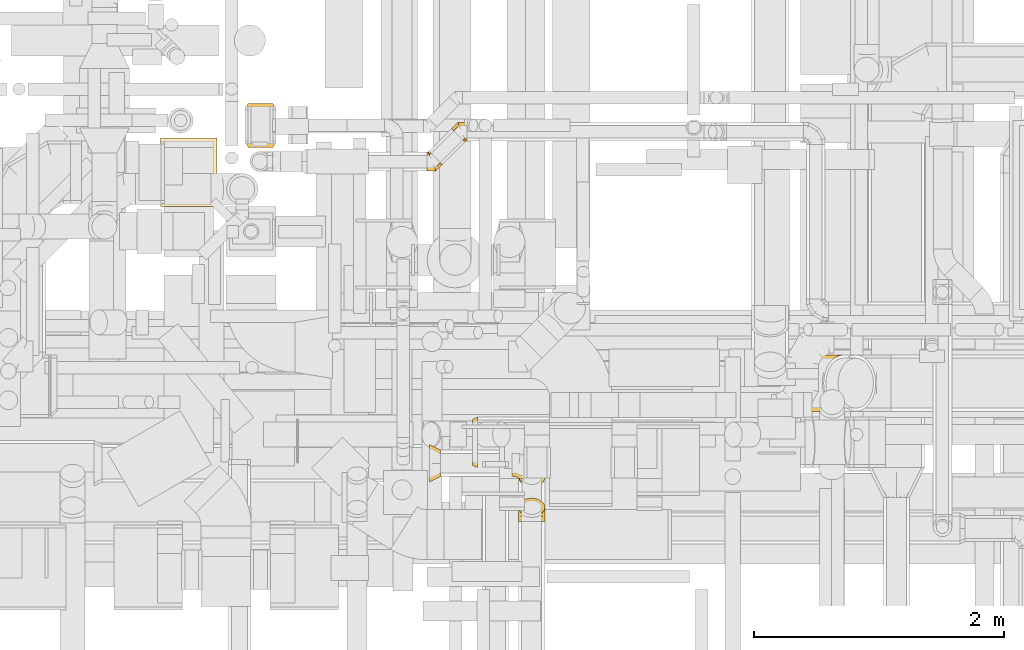
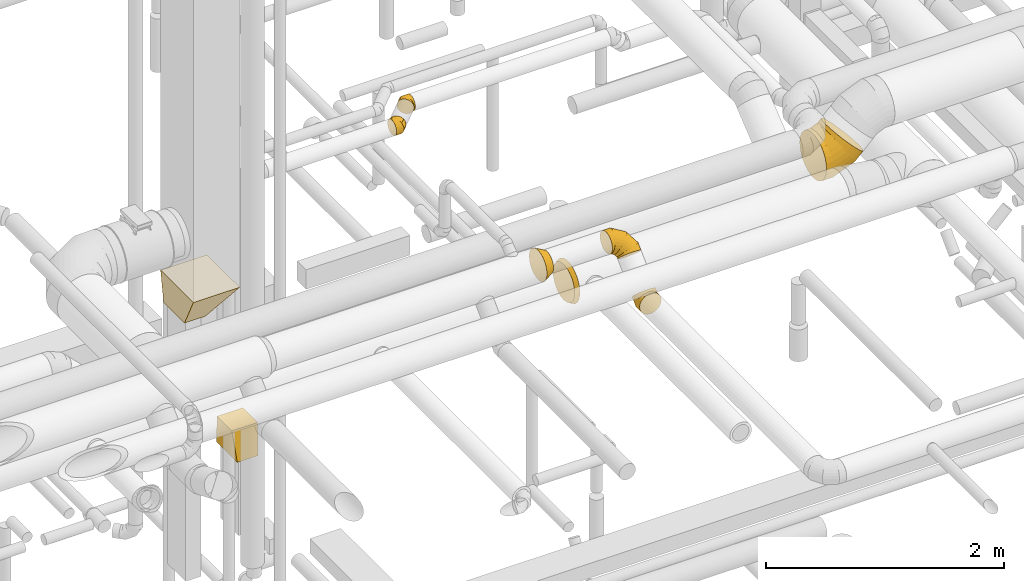
# One storey, part 16 of 337: 9 coverings.
"""IFC2X3 building model written with IfcOpenShell, lengths in millimetres."""

from ifc_helpers import new_model, entity, si_unit, converted_unit, derived_unit, direction, frame, origin, place, context, subcontext, project, spatial, faceted_brep, element, save


model = new_model("IFC2X3")

# Units and contexts
model_context = context("Model", 3, precision=0.01, world=origin(), true_north=direction((6.12303176911189e-17, 1.0)))
body_context = subcontext(model_context, "Body", "Model", "MODEL_VIEW")
ifc_project = project(units=[si_unit("LENGTHUNIT", "METRE", prefix="MILLI"), si_unit("AREAUNIT", "SQUARE_METRE"), si_unit("VOLUMEUNIT", "CUBIC_METRE"), converted_unit("PLANEANGLEUNIT", "DEGREE", entity("IfcRatioMeasure", 0.0174532925199433), si_unit("PLANEANGLEUNIT", "RADIAN"), dimensions=[0, 0, 0, 0, 0, 0, 0]), si_unit("MASSUNIT", "GRAM", prefix="KILO"), derived_unit("MASSDENSITYUNIT", [(si_unit("MASSUNIT", "GRAM", prefix="KILO"), 1), (si_unit("LENGTHUNIT", "METRE"), -3)]), derived_unit("MOMENTOFINERTIAUNIT", [(si_unit("LENGTHUNIT", "METRE"), 4)]), si_unit("TIMEUNIT", "SECOND"), si_unit("FREQUENCYUNIT", "HERTZ"), si_unit("THERMODYNAMICTEMPERATUREUNIT", "DEGREE_CELSIUS"), derived_unit("THERMALTRANSMITTANCEUNIT", [(si_unit("MASSUNIT", "GRAM", prefix="KILO"), 1), (si_unit("THERMODYNAMICTEMPERATUREUNIT", "KELVIN"), -1), (si_unit("TIMEUNIT", "SECOND"), -3)]), derived_unit("VOLUMETRICFLOWRATEUNIT", [(si_unit("LENGTHUNIT", "METRE"), 3), (si_unit("TIMEUNIT", "SECOND"), -1)]), derived_unit("MASSFLOWRATEUNIT", [(si_unit("MASSUNIT", "GRAM", prefix="KILO"), 1), (si_unit("TIMEUNIT", "SECOND"), -1)]), derived_unit("ROTATIONALFREQUENCYUNIT", [(si_unit("TIMEUNIT", "SECOND"), -1)]), si_unit("ELECTRICCURRENTUNIT", "AMPERE"), si_unit("ELECTRICVOLTAGEUNIT", "VOLT"), si_unit("POWERUNIT", "WATT"), si_unit("FORCEUNIT", "NEWTON", prefix="KILO"), si_unit("ILLUMINANCEUNIT", "LUX"), si_unit("LUMINOUSFLUXUNIT", "LUMEN"), si_unit("LUMINOUSINTENSITYUNIT", "CANDELA"), derived_unit("USERDEFINED", [(si_unit("MASSUNIT", "GRAM", prefix="KILO"), -1), (si_unit("LENGTHUNIT", "METRE"), -2), (si_unit("TIMEUNIT", "SECOND"), 3), (si_unit("LUMINOUSFLUXUNIT", "LUMEN"), 1)]), derived_unit("LINEARVELOCITYUNIT", [(si_unit("LENGTHUNIT", "METRE"), 1), (si_unit("TIMEUNIT", "SECOND"), -1)]), si_unit("PRESSUREUNIT", "PASCAL"), derived_unit("USERDEFINED", [(si_unit("LENGTHUNIT", "METRE"), -2), (si_unit("MASSUNIT", "GRAM", prefix="KILO"), 1), (si_unit("TIMEUNIT", "SECOND"), -2)]), derived_unit("LINEARFORCEUNIT", [(si_unit("MASSUNIT", "GRAM", prefix="KILO"), 1), (si_unit("LENGTHUNIT", "METRE"), 1), (si_unit("TIMEUNIT", "SECOND"), -2), (si_unit("LENGTHUNIT", "METRE"), -1)]), derived_unit("PLANARFORCEUNIT", [(si_unit("MASSUNIT", "GRAM", prefix="KILO"), 1), (si_unit("LENGTHUNIT", "METRE"), 1), (si_unit("TIMEUNIT", "SECOND"), -2), (si_unit("LENGTHUNIT", "METRE"), -2)])], contexts=[model_context])

# Site, building, storey
site_placement = place(None, origin())
site = spatial("IfcSite", under=ifc_project, at=site_placement, CompositionType="ELEMENT")
building_placement = place(site_placement, origin())
building = spatial("IfcBuilding", under=site, at=building_placement, CompositionType="ELEMENT")
storey_placement = place(building_placement, origin())
storey = spatial("IfcBuildingStorey", under=building, at=storey_placement, CompositionType="ELEMENT", Elevation=0.0)

# Coverings
covering_1_placement = place(storey_placement, frame((59430.69, 11639.2, 450.0)))
element("IfcCovering", 1, at=covering_1_placement, inside=storey, PredefinedType="INSULATION", context=body_context, shape_type="Brep", body=[
    faceted_brep([(0.0, 50.0, 300.0), (250.0, 50.0, 300.0), (250.0, 300.0, 300.0), (0.0, 300.0, 300.0), (25.0, 0.0, 0.0), (25.0, 350.0, 0.0), (225.0, 350.0, 0.0), (225.0, 0.0, 0.0)], [[[0, 1, 2, 3]], [[4, 5, 6, 7]], [[4, 7, 1, 0]], [[7, 6, 2, 1]], [[6, 5, 3, 2]], [[5, 4, 0, 3]]]),
])
covering_2_placement = place(storey_placement, frame((60888.34, 11448.3, 3373.4)))
element("IfcCovering", 2, at=covering_2_placement, inside=storey, PredefinedType="INSULATION", context=body_context, shape_type="Brep", body=[
    faceted_brep([(18.69, 157.91, 83.77), (19.7, 156.9, 90.95), (21.71, 154.88, 105.3), (27.46, 149.13, 117.46), (33.21, 143.38, 129.63), (41.81, 134.78, 137.76), (50.42, 126.18, 145.89), (60.56, 116.03, 148.74), (70.71, 105.88, 151.6), (80.86, 95.74, 148.74), (91.01, 85.59, 145.89), (99.61, 76.99, 137.76), (108.21, 68.38, 129.63), (113.96, 62.64, 117.46), (119.71, 56.89, 105.3), (121.73, 54.87, 90.95), (123.74, 52.85, 76.6), (121.73, 54.87, 62.24), (119.71, 56.89, 47.89), (113.96, 62.64, 35.73), (108.21, 68.38, 23.56), (99.61, 76.99, 15.43), (91.01, 85.59, 7.3), (80.86, 95.74, 4.45), (70.71, 105.88, 1.6), (60.56, 116.03, 4.45), (50.42, 126.18, 7.3), (41.81, 134.78, 15.43), (33.21, 143.38, 23.56), (27.46, 149.13, 35.73), (21.71, 154.88, 47.89), (19.7, 156.9, 62.24), (18.69, 157.91, 69.42), (17.68, 158.92, 76.6), (0.0, 11.64, 39.1), (0.0, 4.15, 57.18), (0.0, 1.6, 76.6), (0.0, 4.15, 96.01), (0.0, 11.64, 114.1), (0.0, 23.56, 129.63), (0.0, 39.1, 141.55), (0.0, 57.18, 149.04), (0.0, 76.6, 151.6), (0.0, 96.01, 149.04), (0.0, 114.1, 141.55), (0.0, 129.63, 129.63), (0.0, 141.55, 114.1), (0.0, 149.04, 96.01), (0.0, 151.6, 76.6), (0.0, 149.04, 57.18), (0.0, 141.55, 39.1), (0.0, 129.63, 23.56), (0.0, 114.1, 11.64), (0.0, 96.01, 4.15), (0.0, 76.6, 1.6), (0.0, 57.18, 4.15), (0.0, 39.1, 11.64), (0.0, 23.56, 23.56), (72.49, 1.6, 76.6), (71.43, 4.15, 96.01), (68.33, 11.64, 114.1), (63.39, 23.56, 129.63), (56.95, 39.1, 141.55), (49.46, 57.18, 149.04), (41.42, 76.6, 151.6), (33.38, 96.01, 149.04), (25.89, 114.1, 141.55), (19.45, 129.63, 129.63), (14.52, 141.55, 114.1), (12.97, 145.29, 105.05), (11.41, 149.04, 96.01), (10.36, 151.6, 76.6), (10.88, 150.32, 86.3), (11.41, 149.04, 57.18), (12.97, 145.29, 48.14), (14.52, 141.55, 39.1), (10.88, 150.32, 66.89), (19.45, 129.63, 23.56), (33.38, 96.01, 4.15), (41.42, 76.6, 1.6), (25.89, 114.1, 11.64), (49.46, 57.18, 4.15), (56.95, 39.1, 11.64), (63.39, 23.56, 23.56), (68.33, 11.64, 39.1), (71.43, 4.15, 57.18)], [[[0, 1, 2, 3, 4, 5, 6, 7, 8, 9, 10, 11, 12, 13, 14, 15, 16, 17, 18, 19, 20, 21, 22, 23, 24, 25, 26, 27, 28, 29, 30, 31, 32, 33]], [[34, 35, 36, 37, 38, 39, 40, 41, 42, 43, 44, 45, 46, 47, 48, 49, 50, 51, 52, 53, 54, 55, 56, 57]], [[36, 58, 59, 37]], [[37, 59, 60, 38]], [[61, 39, 38, 60]], [[39, 61, 62, 40]], [[40, 62, 63, 41]], [[64, 42, 41, 63]], [[65, 66, 44, 43]], [[64, 65, 43, 42]], [[67, 45, 44, 66]], [[46, 68, 69, 70, 47]], [[68, 46, 45, 67]], [[71, 48, 47, 70, 72]], [[50, 49, 73, 74, 75]], [[49, 48, 71, 76, 73]], [[51, 50, 75, 77]], [[78, 79, 54, 53]], [[80, 78, 53, 52]], [[77, 80, 52, 51]], [[55, 54, 79, 81]], [[56, 55, 81, 82]], [[82, 83, 57, 56]], [[35, 34, 84, 85]], [[36, 35, 85, 58]], [[83, 84, 34, 57]], [[58, 15, 59]], [[15, 58, 16]], [[13, 12, 61]], [[13, 61, 60]], [[60, 14, 13]], [[59, 14, 60]], [[11, 10, 62]], [[61, 11, 62]], [[15, 14, 59]], [[11, 61, 12]], [[8, 64, 9]], [[10, 63, 62]], [[64, 63, 9]], [[63, 10, 9]], [[65, 8, 7, 6]], [[4, 67, 5]], [[72, 1, 0]], [[66, 6, 5]], [[66, 65, 6]], [[71, 0, 33]], [[66, 5, 67]], [[71, 72, 0]], [[8, 65, 64]], [[1, 72, 70]], [[2, 70, 69, 68]], [[4, 3, 67]], [[67, 3, 68]], [[70, 2, 1]], [[68, 3, 2]], [[73, 31, 30]], [[29, 28, 77]], [[30, 75, 74, 73]], [[32, 31, 76]], [[32, 71, 33]], [[77, 75, 29]], [[27, 77, 28]], [[78, 26, 25, 24]], [[77, 27, 80]], [[71, 32, 76]], [[78, 80, 26]], [[78, 24, 79]], [[31, 73, 76]], [[75, 30, 29]], [[27, 26, 80]], [[82, 22, 21]], [[79, 23, 81]], [[22, 82, 81]], [[21, 83, 82]], [[19, 83, 20]], [[23, 22, 81]], [[20, 83, 21]], [[23, 79, 24]], [[83, 19, 84]], [[16, 58, 17]], [[18, 85, 84]], [[58, 85, 17]], [[85, 18, 17]], [[19, 18, 84]]]),
])
covering_3_placement = place(storey_placement, frame((61083.53, 11678.67, 3373.4)))
element("IfcCovering", 3, at=covering_3_placement, inside=storey, PredefinedType="INSULATION", context=body_context, shape_type="Brep", body=[
    faceted_brep([(106.65, 2.6, 83.77), (105.64, 3.61, 90.95), (103.62, 5.63, 105.3), (97.88, 11.38, 117.46), (92.13, 17.13, 129.63), (83.53, 25.73, 137.76), (74.92, 34.33, 145.89), (64.78, 44.48, 148.74), (54.63, 54.63, 151.6), (44.48, 64.78, 148.74), (34.33, 74.92, 145.89), (25.73, 83.53, 137.76), (17.13, 92.13, 129.63), (11.38, 97.88, 117.46), (5.63, 103.62, 105.3), (3.61, 105.64, 90.95), (1.6, 107.66, 76.6), (3.61, 105.64, 62.24), (5.63, 103.62, 47.89), (11.38, 97.88, 35.73), (17.13, 92.13, 23.56), (25.73, 83.53, 15.43), (34.33, 74.92, 7.3), (44.48, 64.78, 4.45), (54.63, 54.63, 1.6), (64.78, 44.48, 4.45), (74.92, 34.33, 7.3), (83.53, 25.73, 15.43), (92.13, 17.13, 23.56), (97.88, 11.38, 35.73), (103.62, 5.63, 47.89), (105.64, 3.61, 62.24), (106.65, 2.6, 69.42), (107.66, 1.6, 76.6), (125.34, 148.87, 39.1), (125.34, 156.36, 57.18), (125.34, 158.92, 76.6), (125.34, 156.36, 96.01), (125.34, 148.87, 114.1), (125.34, 136.95, 129.63), (125.34, 121.42, 141.55), (125.34, 103.33, 149.04), (125.34, 83.92, 151.6), (125.34, 64.51, 149.04), (125.34, 46.42, 141.55), (125.34, 30.88, 129.63), (125.34, 18.97, 114.1), (125.34, 11.47, 96.01), (125.34, 8.92, 76.6), (125.34, 11.47, 57.18), (125.34, 18.97, 39.1), (125.34, 30.88, 23.56), (125.34, 46.42, 11.64), (125.34, 64.51, 4.15), (125.34, 83.92, 1.6), (125.34, 103.33, 4.15), (125.34, 121.42, 11.64), (125.34, 136.95, 23.56), (52.85, 158.92, 76.6), (53.91, 156.36, 96.01), (57.01, 148.87, 114.1), (61.95, 136.95, 129.63), (68.38, 121.42, 141.55), (75.88, 103.33, 149.04), (83.92, 83.92, 151.6), (91.96, 64.51, 149.04), (99.45, 46.42, 141.55), (105.88, 30.88, 129.63), (110.82, 18.97, 114.1), (112.37, 15.22, 105.05), (113.93, 11.47, 96.01), (114.98, 8.92, 76.6), (114.45, 10.2, 86.3), (113.93, 11.47, 57.18), (112.37, 15.22, 48.14), (110.82, 18.97, 39.1), (114.45, 10.2, 66.89), (105.88, 30.88, 23.56), (91.96, 64.51, 4.15), (83.92, 83.92, 1.6), (99.45, 46.42, 11.64), (75.88, 103.33, 4.15), (68.38, 121.42, 11.64), (61.95, 136.95, 23.56), (57.01, 148.87, 39.1), (53.91, 156.36, 57.18)], [[[0, 1, 2, 3, 4, 5, 6, 7, 8, 9, 10, 11, 12, 13, 14, 15, 16, 17, 18, 19, 20, 21, 22, 23, 24, 25, 26, 27, 28, 29, 30, 31, 32, 33]], [[34, 35, 36, 37, 38, 39, 40, 41, 42, 43, 44, 45, 46, 47, 48, 49, 50, 51, 52, 53, 54, 55, 56, 57]], [[36, 58, 59, 37]], [[37, 59, 60, 38]], [[61, 39, 38, 60]], [[39, 61, 62, 40]], [[40, 62, 63, 41]], [[64, 42, 41, 63]], [[65, 66, 44, 43]], [[64, 65, 43, 42]], [[67, 45, 44, 66]], [[46, 68, 69, 70, 47]], [[68, 46, 45, 67]], [[71, 48, 47, 70, 72]], [[50, 49, 73, 74, 75]], [[49, 48, 71, 76, 73]], [[51, 50, 75, 77]], [[78, 79, 54, 53]], [[80, 78, 53, 52]], [[77, 80, 52, 51]], [[55, 54, 79, 81]], [[56, 55, 81, 82]], [[82, 83, 57, 56]], [[35, 34, 84, 85]], [[36, 35, 85, 58]], [[83, 84, 34, 57]], [[58, 15, 59]], [[15, 58, 16]], [[13, 12, 61]], [[13, 61, 60]], [[60, 14, 13]], [[59, 14, 60]], [[11, 10, 62]], [[61, 11, 62]], [[15, 14, 59]], [[11, 61, 12]], [[8, 64, 9]], [[10, 63, 62]], [[64, 63, 9]], [[63, 10, 9]], [[65, 8, 7, 6]], [[4, 67, 5]], [[72, 1, 0]], [[66, 6, 5]], [[66, 65, 6]], [[71, 0, 33]], [[66, 5, 67]], [[71, 72, 0]], [[8, 65, 64]], [[1, 72, 70]], [[2, 70, 69, 68]], [[4, 3, 67]], [[67, 3, 68]], [[70, 2, 1]], [[68, 3, 2]], [[73, 31, 30]], [[29, 28, 77]], [[30, 75, 74, 73]], [[32, 31, 76]], [[32, 71, 33]], [[77, 75, 29]], [[27, 77, 28]], [[78, 26, 25, 24]], [[77, 27, 80]], [[71, 32, 76]], [[78, 80, 26]], [[78, 24, 79]], [[31, 73, 76]], [[75, 30, 29]], [[27, 26, 80]], [[82, 22, 21]], [[79, 23, 81]], [[22, 82, 81]], [[21, 83, 82]], [[19, 83, 20]], [[23, 22, 81]], [[20, 83, 21]], [[23, 79, 24]], [[83, 19, 84]], [[16, 58, 17]], [[18, 85, 84]], [[58, 85, 17]], [[85, 18, 17]], [[19, 18, 84]]]),
])
covering_4_placement = place(storey_placement, frame((61620.81, 8642.38, 2993.4)))
element("IfcCovering", 4, at=covering_4_placement, inside=storey, PredefinedType="INSULATION", context=body_context, shape_type="Brep", body=[
    faceted_brep([(106.6, 38.89, 227.7), (139.04, 42.52, 224.07), (168.31, 53.07, 213.52), (191.54, 69.5, 197.1), (206.46, 90.19, 176.4), (211.6, 113.14, 153.46), (206.46, 136.08, 130.51), (191.54, 156.78, 109.82), (168.31, 173.2, 93.39), (139.04, 183.75, 82.85), (106.6, 187.38, 79.21), (74.15, 183.75, 82.85), (44.88, 173.2, 93.39), (21.65, 156.78, 109.82), (6.73, 136.08, 130.51), (1.6, 113.14, 153.46), (6.73, 90.19, 176.4), (21.65, 69.5, 197.1), (44.88, 53.07, 213.52), (74.15, 42.52, 224.07), (54.1, 0.0, 15.66), (79.42, 0.0, 5.17), (106.6, 0.0, 1.6), (133.77, 0.0, 5.17), (159.1, 0.0, 15.66), (180.84, 0.0, 32.35), (197.53, 0.0, 54.1), (208.02, 0.0, 79.42), (211.6, 0.0, 106.6), (208.02, 0.0, 133.77), (197.53, 0.0, 159.1), (180.84, 0.0, 180.84), (159.1, 0.0, 197.53), (133.77, 0.0, 208.02), (106.6, 0.0, 211.6), (79.42, 0.0, 208.02), (54.1, 0.0, 197.53), (32.35, 0.0, 180.84), (15.66, 0.0, 159.1), (5.17, 0.0, 133.77), (1.6, 0.0, 106.6), (5.17, 0.0, 79.42), (15.66, 0.0, 54.1), (32.35, 0.0, 32.35), (106.6, 109.77, 1.6), (133.77, 108.28, 5.17), (159.1, 103.94, 15.66), (180.84, 97.03, 32.35), (197.53, 88.02, 54.1), (208.02, 77.53, 79.42), (211.6, 66.27, 106.6), (208.02, 55.02, 133.77), (197.53, 44.53, 159.1), (180.84, 35.52, 180.84), (133.77, 24.26, 208.02), (106.6, 22.78, 211.6), (159.1, 28.61, 197.53), (54.1, 28.61, 197.53), (32.35, 35.52, 180.84), (79.42, 24.26, 208.02), (5.17, 55.02, 133.77), (1.6, 66.27, 106.6), (15.66, 44.53, 159.1), (5.17, 77.53, 79.42), (15.66, 88.02, 54.1), (32.35, 97.03, 32.35), (54.1, 103.94, 15.66), (79.42, 108.28, 5.17)], [[[0, 1, 2, 3, 4, 5, 6, 7, 8, 9, 10, 11, 12, 13, 14, 15, 16, 17, 18, 19]], [[20, 21, 22, 23, 24, 25, 26, 27, 28, 29, 30, 31, 32, 33, 34, 35, 36, 37, 38, 39, 40, 41, 42, 43]], [[22, 44, 45, 23]], [[23, 45, 46, 24]], [[47, 25, 24, 46]], [[25, 47, 48, 26]], [[26, 48, 49, 27]], [[50, 28, 27, 49]], [[51, 52, 30, 29]], [[50, 51, 29, 28]], [[30, 52, 53, 31]], [[54, 55, 34, 33]], [[56, 54, 33, 32]], [[31, 53, 56, 32]], [[36, 57, 58, 37]], [[59, 57, 36, 35]], [[34, 55, 59, 35]], [[60, 61, 40, 39]], [[62, 60, 39, 38]], [[58, 62, 38, 37]], [[41, 40, 61, 63]], [[42, 41, 63, 64]], [[64, 65, 43, 42]], [[21, 20, 66, 67]], [[22, 21, 67, 44]], [[65, 66, 20, 43]], [[9, 8, 46]], [[10, 9, 45]], [[10, 45, 44]], [[45, 9, 46]], [[8, 47, 46]], [[48, 7, 6]], [[49, 6, 5]], [[47, 7, 48]], [[48, 6, 49]], [[5, 50, 49]], [[7, 47, 8]], [[51, 5, 4]], [[52, 4, 3]], [[51, 50, 5]], [[52, 51, 4]], [[3, 53, 52]], [[56, 2, 1]], [[54, 1, 0]], [[56, 53, 2]], [[55, 54, 0]], [[56, 1, 54]], [[2, 53, 3]], [[19, 18, 57]], [[0, 19, 59]], [[59, 55, 0]], [[57, 59, 19]], [[18, 58, 57]], [[62, 17, 16]], [[60, 16, 15]], [[62, 58, 17]], [[61, 60, 15]], [[62, 16, 60]], [[17, 58, 18]], [[63, 15, 14]], [[64, 14, 13]], [[15, 63, 61]], [[63, 14, 64]], [[13, 65, 64]], [[66, 12, 11]], [[67, 11, 10]], [[65, 12, 66]], [[67, 66, 11]], [[44, 67, 10]], [[12, 65, 13]]]),
])
covering_5_placement = place(storey_placement, frame((61567.4, 8919.67, 3311.05)))
element("IfcCovering", 5, at=covering_5_placement, inside=storey, PredefinedType="INSULATION", context=body_context, shape_type="Brep", body=[
    faceted_brep([(0.0, 85.27, 205.4), (0.0, 95.42, 236.65), (0.0, 114.73, 263.22), (0.0, 141.31, 282.53), (0.0, 172.55, 292.69), (0.0, 205.4, 292.69), (0.0, 236.65, 282.53), (0.0, 263.22, 263.22), (0.0, 282.53, 236.65), (0.0, 292.69, 205.4), (0.0, 292.69, 172.55), (0.0, 282.53, 141.31), (0.0, 263.22, 114.73), (0.0, 236.65, 95.42), (0.0, 205.4, 85.27), (0.0, 172.55, 85.27), (0.0, 141.31, 95.42), (0.0, 114.73, 114.73), (0.0, 95.42, 141.31), (0.0, 85.27, 172.55), (250.93, 112.96, 38.72), (261.42, 95.06, 56.63), (265.0, 75.84, 75.84), (261.42, 56.63, 95.06), (250.93, 38.72, 112.96), (234.25, 23.34, 128.34), (212.5, 11.54, 140.14), (187.18, 4.13, 147.56), (160.0, 1.6, 150.09), (132.82, 4.13, 147.56), (107.5, 11.54, 140.14), (85.75, 23.34, 128.34), (69.07, 38.72, 112.96), (58.58, 56.63, 95.06), (55.0, 75.84, 75.84), (58.58, 95.06, 56.63), (69.07, 112.96, 38.72), (85.75, 128.34, 23.34), (107.5, 140.14, 11.54), (132.82, 147.56, 4.13), (160.0, 150.09, 1.6), (187.18, 147.56, 4.13), (212.5, 140.14, 11.54), (234.25, 128.34, 23.34), (265.0, 126.05, 126.05), (261.42, 106.16, 144.59), (250.93, 86.26, 160.51), (234.25, 67.72, 172.72), (212.5, 51.8, 180.4), (187.18, 39.59, 183.02), (160.0, 31.91, 180.4), (132.82, 29.29, 172.72), (107.5, 31.91, 160.51), (85.75, 39.59, 144.59), (69.07, 51.8, 126.05), (58.58, 67.72, 106.16), (55.0, 86.26, 86.26), (58.58, 106.16, 67.72), (69.07, 126.05, 51.8), (85.75, 144.59, 39.59), (132.82, 172.72, 29.29), (160.0, 180.4, 31.91), (107.5, 160.51, 31.91), (187.18, 183.02, 39.59), (212.5, 180.4, 51.8), (234.25, 172.72, 67.72), (250.93, 160.51, 86.26), (261.42, 144.59, 106.16), (193.99, 213.02, 213.02), (191.37, 191.95, 230.38), (183.7, 168.61, 242.86), (171.48, 144.6, 249.6), (155.56, 121.54, 250.14), (137.02, 101.01, 244.45), (117.13, 84.42, 232.91), (97.23, 72.88, 216.31), (78.7, 67.19, 195.79), (62.78, 67.73, 172.73), (50.56, 74.47, 148.72), (42.88, 86.95, 125.38), (40.26, 104.31, 104.31), (42.88, 125.38, 86.95), (50.56, 148.72, 74.47), (62.78, 172.73, 67.73), (97.23, 216.31, 72.88), (117.13, 232.91, 84.42), (78.7, 195.79, 67.19), (137.02, 244.45, 101.01), (155.56, 250.14, 121.54), (171.48, 249.6, 144.6), (183.7, 242.86, 168.61), (191.37, 230.38, 191.95), (71.01, 263.22, 263.22), (70.05, 241.48, 279.91), (67.24, 216.15, 290.4), (62.77, 188.98, 293.98), (56.94, 161.8, 290.4), (50.15, 136.48, 279.91), (42.87, 114.73, 263.22), (35.59, 98.05, 241.48), (28.8, 87.56, 216.15), (22.98, 83.98, 188.98), (18.51, 87.56, 161.8), (15.7, 98.05, 136.48), (14.74, 114.73, 114.73), (15.7, 136.48, 98.05), (18.51, 161.8, 87.56), (22.98, 188.98, 83.98), (35.59, 241.48, 98.05), (42.87, 263.22, 114.73), (28.8, 216.15, 87.56), (50.15, 279.91, 136.48), (56.94, 290.4, 161.8), (62.77, 293.98, 188.98), (67.24, 290.4, 216.15), (70.05, 279.91, 241.48)], [[[0, 1, 2, 3, 4, 5, 6, 7, 8, 9, 10, 11, 12, 13, 14, 15, 16, 17, 18, 19]], [[20, 21, 22, 23, 24, 25, 26, 27, 28, 29, 30, 31, 32, 33, 34, 35, 36, 37, 38, 39, 40, 41, 42, 43]], [[22, 44, 45, 23]], [[23, 45, 46, 24]], [[24, 46, 47, 25]], [[25, 47, 48, 26]], [[26, 48, 49, 27]], [[50, 28, 27, 49]], [[51, 52, 30, 29]], [[50, 51, 29, 28]], [[53, 31, 30, 52]], [[54, 55, 33, 32]], [[54, 32, 31, 53]], [[56, 34, 33, 55]], [[57, 58, 36, 35]], [[56, 57, 35, 34]], [[37, 36, 58, 59]], [[60, 61, 40, 39]], [[62, 60, 39, 38]], [[59, 62, 38, 37]], [[41, 40, 61, 63]], [[42, 41, 63, 64]], [[64, 65, 43, 42]], [[21, 20, 66, 67]], [[22, 21, 67, 44]], [[65, 66, 20, 43]], [[45, 44, 68, 69]], [[46, 45, 69, 70]], [[70, 71, 47, 46]], [[48, 47, 71, 72]], [[49, 48, 72, 73]], [[50, 49, 73, 74]], [[75, 76, 52, 51]], [[74, 75, 51, 50]], [[53, 52, 76, 77]], [[78, 79, 55, 54]], [[77, 78, 54, 53]], [[56, 55, 79, 80]], [[81, 82, 58, 57]], [[80, 81, 57, 56]], [[59, 58, 82, 83]], [[84, 85, 61, 60]], [[86, 84, 60, 62]], [[83, 86, 62, 59]], [[63, 61, 85, 87]], [[64, 63, 87, 88]], [[65, 64, 88, 89]], [[67, 66, 90, 91]], [[44, 67, 91, 68]], [[89, 90, 66, 65]], [[69, 68, 92, 93]], [[70, 69, 93, 94]], [[94, 95, 71, 70]], [[72, 71, 95, 96]], [[73, 72, 96, 97]], [[74, 73, 97, 98]], [[99, 100, 76, 75]], [[98, 99, 75, 74]], [[77, 76, 100, 101]], [[102, 103, 79, 78]], [[101, 102, 78, 77]], [[80, 79, 103, 104]], [[105, 106, 82, 81]], [[104, 105, 81, 80]], [[83, 82, 106, 107]], [[108, 109, 85, 84]], [[110, 108, 84, 86]], [[107, 110, 86, 83]], [[87, 85, 109, 111]], [[88, 87, 111, 112]], [[89, 88, 112, 113]], [[91, 90, 114, 115]], [[68, 91, 115, 92]], [[113, 114, 90, 89]], [[93, 7, 6]], [[94, 6, 5]], [[7, 93, 92]], [[93, 6, 94]], [[5, 95, 94]], [[96, 4, 3]], [[97, 3, 2]], [[95, 4, 96]], [[96, 3, 97]], [[2, 98, 97]], [[4, 95, 5]], [[99, 2, 1]], [[100, 1, 0]], [[99, 98, 2]], [[100, 99, 1]], [[0, 101, 100]], [[102, 19, 18]], [[103, 18, 17]], [[102, 101, 19]], [[104, 103, 17]], [[102, 18, 103]], [[19, 101, 0]], [[105, 17, 16]], [[106, 16, 15]], [[105, 104, 17]], [[106, 105, 16]], [[15, 107, 106]], [[110, 14, 13]], [[108, 13, 12]], [[110, 107, 14]], [[109, 108, 12]], [[110, 13, 108]], [[14, 107, 15]], [[11, 10, 112]], [[12, 11, 111]], [[12, 111, 109]], [[111, 11, 112]], [[10, 113, 112]], [[114, 9, 8]], [[115, 8, 7]], [[113, 9, 114]], [[115, 114, 8]], [[92, 115, 7]], [[9, 113, 10]]]),
])
covering_6_placement = place(storey_placement, frame((60907.4, 8957.05, 3348.43)))
element("IfcCovering", 6, at=covering_6_placement, inside=storey, PredefinedType="INSULATION", context=body_context, shape_type="Brep", body=[
    faceted_brep([(0.0, 226.6, 281.5), (0.0, 257.66, 257.66), (0.0, 281.5, 226.6), (0.0, 296.48, 190.42), (0.0, 301.6, 151.6), (0.0, 296.48, 112.77), (0.0, 281.5, 76.6), (0.0, 257.66, 45.53), (0.0, 226.6, 21.69), (0.0, 190.42, 6.71), (0.0, 151.6, 1.6), (0.0, 112.77, 6.71), (0.0, 76.6, 21.69), (0.0, 45.53, 45.53), (0.0, 21.69, 76.6), (0.0, 6.71, 112.77), (0.0, 1.6, 151.6), (0.0, 6.71, 190.42), (0.0, 21.69, 226.6), (0.0, 45.53, 257.66), (0.0, 76.6, 281.5), (0.0, 112.77, 296.48), (0.0, 151.6, 301.6), (0.0, 190.42, 296.48), (90.0, 184.04, 251.46), (90.0, 151.6, 256.6), (90.0, 119.15, 251.46), (90.0, 89.88, 236.54), (90.0, 66.65, 213.31), (90.0, 51.73, 184.04), (90.0, 46.6, 151.6), (90.0, 51.73, 119.15), (90.0, 66.65, 89.88), (90.0, 89.88, 66.65), (90.0, 119.15, 51.73), (90.0, 151.6, 46.6), (90.0, 184.04, 51.73), (90.0, 213.31, 66.65), (90.0, 236.54, 89.88), (90.0, 251.46, 119.15), (90.0, 256.6, 151.6), (90.0, 251.46, 184.04), (90.0, 236.54, 213.31), (90.0, 213.31, 236.54)], [[[0, 1, 2, 3, 4, 5, 6, 7, 8, 9, 10, 11, 12, 13, 14, 15, 16, 17, 18, 19, 20, 21, 22, 23]], [[24, 25, 26, 27, 28, 29, 30, 31, 32, 33, 34, 35, 36, 37, 38, 39, 40, 41, 42, 43]], [[5, 40, 39]], [[6, 39, 38]], [[5, 4, 40]], [[6, 5, 39]], [[38, 7, 6]], [[36, 35, 9]], [[37, 36, 8]], [[7, 37, 8]], [[9, 8, 36]], [[10, 9, 35]], [[37, 7, 38]], [[11, 35, 34]], [[12, 34, 33]], [[11, 10, 35]], [[12, 11, 34]], [[33, 13, 12]], [[31, 30, 15]], [[32, 31, 14]], [[13, 32, 14]], [[15, 14, 31]], [[16, 15, 30]], [[32, 13, 33]], [[17, 30, 29]], [[18, 29, 28]], [[17, 16, 30]], [[18, 17, 29]], [[28, 19, 18]], [[26, 25, 21]], [[27, 26, 20]], [[19, 27, 20]], [[21, 20, 26]], [[22, 21, 25]], [[27, 19, 28]], [[23, 25, 24]], [[0, 24, 43]], [[23, 22, 25]], [[0, 23, 24]], [[43, 1, 0]], [[41, 40, 3]], [[42, 41, 2]], [[1, 42, 2]], [[3, 2, 41]], [[4, 3, 40]], [[42, 1, 43]]]),
])
covering_7_placement = place(storey_placement, frame((63941.82, 9523.4, 2941.44)))
element("IfcCovering", 7, at=covering_7_placement, inside=storey, PredefinedType="INSULATION", context=body_context, shape_type="Brep", body=[
    faceted_brep([(0.0, 226.6, 451.6), (0.0, 276.66, 445.95), (0.0, 324.22, 429.31), (0.0, 366.88, 402.51), (0.0, 402.51, 366.88), (0.0, 429.31, 324.22), (0.0, 445.95, 276.66), (0.0, 451.6, 226.6), (0.0, 445.95, 176.53), (0.0, 429.31, 128.97), (0.0, 402.51, 86.31), (0.0, 366.88, 50.68), (0.0, 324.22, 23.88), (0.0, 276.66, 7.24), (0.0, 226.6, 1.6), (0.0, 176.53, 7.24), (0.0, 128.97, 23.88), (0.0, 86.31, 50.68), (0.0, 50.68, 86.31), (0.0, 23.88, 128.97), (0.0, 7.24, 176.53), (0.0, 1.6, 226.6), (0.0, 7.24, 276.66), (0.0, 23.88, 324.22), (0.0, 50.68, 366.88), (0.0, 86.31, 402.51), (0.0, 128.97, 429.31), (0.0, 176.53, 445.95), (407.23, 86.31, 219.36), (426.19, 128.97, 200.41), (437.95, 176.53, 188.64), (441.94, 226.6, 184.65), (437.95, 276.66, 188.64), (426.19, 324.22, 200.41), (407.23, 366.88, 219.36), (382.04, 402.51, 244.56), (351.87, 429.31, 274.72), (318.25, 445.95, 308.35), (282.84, 451.6, 343.75), (247.44, 445.95, 379.16), (213.81, 429.31, 412.78), (183.65, 402.51, 442.95), (158.45, 366.88, 468.14), (139.5, 324.22, 487.1), (127.73, 276.66, 498.86), (123.74, 226.6, 502.85), (127.73, 176.53, 498.86), (139.5, 128.97, 487.1), (158.45, 86.31, 468.14), (183.65, 50.68, 442.95), (213.81, 23.88, 412.78), (247.44, 7.24, 379.16), (282.84, 1.6, 343.75), (318.25, 7.24, 308.35), (351.87, 23.88, 274.72), (382.04, 50.68, 244.56), (354.03, 226.6, 96.75), (350.84, 276.66, 101.53), (341.41, 324.22, 115.64), (326.23, 366.88, 138.36), (306.05, 402.51, 168.56), (281.88, 429.31, 204.73), (254.94, 445.95, 245.05), (226.58, 451.6, 287.49), (198.22, 445.95, 329.94), (171.28, 429.31, 370.25), (147.12, 402.51, 406.42), (126.94, 366.88, 436.62), (111.75, 324.22, 459.35), (102.33, 276.66, 473.46), (99.13, 226.6, 478.24), (102.33, 176.53, 473.46), (111.75, 128.97, 459.35), (126.94, 86.31, 436.62), (147.12, 50.68, 406.42), (171.28, 23.88, 370.25), (198.22, 7.24, 329.94), (226.58, 1.6, 287.49), (254.94, 7.24, 245.05), (281.88, 23.88, 204.73), (306.05, 50.68, 168.56), (326.23, 86.31, 138.36), (341.41, 128.97, 115.64), (350.84, 176.53, 101.53), (124.32, 226.6, 1.6), (123.2, 276.66, 7.24), (119.89, 324.22, 23.88), (114.56, 366.88, 50.68), (107.47, 402.51, 86.31), (98.98, 429.31, 128.97), (89.52, 445.95, 176.53), (79.56, 451.6, 226.6), (69.61, 445.95, 276.66), (60.15, 429.31, 324.22), (51.66, 402.51, 366.88), (44.57, 366.88, 402.51), (39.24, 324.22, 429.31), (35.93, 276.66, 445.95), (34.81, 226.6, 451.6), (35.93, 176.53, 445.95), (39.24, 128.97, 429.31), (44.57, 86.31, 402.51), (51.66, 50.68, 366.88), (60.15, 23.88, 324.22), (69.61, 7.24, 276.66), (79.56, 1.6, 226.6), (89.52, 7.24, 176.53), (98.98, 23.88, 128.97), (107.47, 50.68, 86.31), (114.56, 86.31, 50.68), (119.89, 128.97, 23.88), (123.2, 176.53, 7.24)], [[[0, 1, 2, 3, 4, 5, 6, 7, 8, 9, 10, 11, 12, 13, 14, 15, 16, 17, 18, 19, 20, 21, 22, 23, 24, 25, 26, 27]], [[28, 29, 30, 31, 32, 33, 34, 35, 36, 37, 38, 39, 40, 41, 42, 43, 44, 45, 46, 47, 48, 49, 50, 51, 52, 53, 54, 55]], [[31, 56, 57, 32]], [[32, 57, 58, 33]], [[33, 58, 59, 34]], [[59, 60, 35, 34]], [[35, 60, 61, 36]], [[36, 61, 62, 37]], [[37, 62, 63, 38]], [[63, 64, 39, 38]], [[65, 66, 41, 40]], [[64, 65, 40, 39]], [[66, 67, 42, 41]], [[67, 68, 43, 42]], [[69, 70, 45, 44]], [[68, 69, 44, 43]], [[70, 71, 46, 45]], [[72, 73, 48, 47]], [[71, 72, 47, 46]], [[73, 74, 49, 48]], [[74, 75, 50, 49]], [[76, 77, 52, 51]], [[75, 76, 51, 50]], [[53, 52, 77, 78]], [[78, 79, 54, 53]], [[80, 55, 54, 79]], [[80, 81, 28, 55]], [[29, 28, 81, 82]], [[82, 83, 30, 29]], [[56, 31, 30, 83]], [[56, 84, 85, 57]], [[57, 85, 86, 58]], [[59, 58, 86, 87]], [[87, 88, 60, 59]], [[61, 60, 88, 89]], [[62, 61, 89, 90]], [[63, 62, 90, 91]], [[91, 92, 64, 63]], [[93, 94, 66, 65]], [[92, 93, 65, 64]], [[94, 95, 67, 66]], [[95, 96, 68, 67]], [[97, 98, 70, 69]], [[96, 97, 69, 68]], [[98, 99, 71, 70]], [[100, 101, 73, 72]], [[99, 100, 72, 71]], [[101, 102, 74, 73]], [[102, 103, 75, 74]], [[104, 105, 77, 76]], [[103, 104, 76, 75]], [[78, 77, 105, 106]], [[106, 107, 79, 78]], [[108, 80, 79, 107]], [[108, 109, 81, 80]], [[82, 81, 109, 110]], [[110, 111, 83, 82]], [[84, 56, 83, 111]], [[85, 84, 14, 13]], [[12, 11, 87, 86]], [[86, 85, 13, 12]], [[11, 10, 88, 87]], [[89, 88, 10, 9]], [[90, 89, 9, 8]], [[91, 90, 8, 7]], [[92, 91, 7, 6]], [[6, 5, 93, 92]], [[4, 94, 93, 5]], [[4, 3, 95, 94]], [[3, 2, 96, 95]], [[2, 1, 97, 96]], [[98, 97, 1, 0]], [[98, 0, 27, 99]], [[27, 26, 100, 99]], [[25, 101, 100, 26]], [[25, 24, 102, 101]], [[102, 24, 23, 103]], [[22, 21, 105, 104]], [[103, 23, 22, 104]], [[105, 21, 20, 106]], [[106, 20, 19, 107]], [[107, 19, 18, 108]], [[18, 17, 109, 108]], [[109, 17, 16, 110]], [[110, 16, 15, 111]], [[111, 15, 14, 84]]]),
])
covering_8_placement = place(storey_placement, frame((61253.27, 9071.79, 2895.9)))
element("IfcCovering", 8, at=covering_8_placement, inside=storey, PredefinedType="INSULATION", context=body_context, shape_type="Brep", body=[
    faceted_brep([(40.0, 204.1, 406.6), (40.0, 159.03, 401.52), (40.0, 116.23, 386.54), (40.0, 77.84, 362.42), (40.0, 45.77, 330.35), (40.0, 21.65, 291.96), (40.0, 6.67, 249.16), (40.0, 1.6, 204.1), (40.0, 6.67, 159.03), (40.0, 21.65, 116.23), (40.0, 45.77, 77.84), (40.0, 77.84, 45.77), (40.0, 116.23, 21.65), (40.0, 159.03, 6.67), (40.0, 204.1, 1.6), (40.0, 249.16, 6.67), (40.0, 291.96, 21.65), (40.0, 330.35, 45.77), (40.0, 362.42, 77.84), (40.0, 386.54, 116.23), (40.0, 401.52, 159.03), (40.0, 406.6, 204.1), (40.0, 401.52, 249.16), (40.0, 386.54, 291.96), (40.0, 362.42, 330.35), (40.0, 330.35, 362.42), (40.0, 291.96, 386.54), (40.0, 249.16, 401.52), (0.0, 251.33, 380.38), (0.0, 295.35, 362.15), (0.0, 333.14, 333.14), (0.0, 362.14, 295.35), (0.0, 380.38, 251.33), (0.0, 386.6, 204.1), (0.0, 380.38, 156.86), (0.0, 362.14, 112.85), (0.0, 333.14, 75.05), (0.0, 295.35, 46.05), (0.0, 251.33, 27.81), (0.0, 204.1, 21.6), (0.0, 156.86, 27.81), (0.0, 112.85, 46.05), (0.0, 75.05, 75.05), (0.0, 46.05, 112.85), (0.0, 27.81, 156.86), (0.0, 21.6, 204.1), (0.0, 27.81, 251.33), (0.0, 46.05, 295.35), (0.0, 75.05, 333.14), (0.0, 112.85, 362.15), (0.0, 156.86, 380.38), (0.0, 204.1, 386.6), (24.42, 204.1, 9.38), (20.93, 21.96, 140.36), (21.49, 40.47, 101.28), (24.42, 9.38, 204.1), (20.93, 140.36, 21.96), (21.49, 101.28, 40.47), (21.11, 65.03, 70.18), (24.42, 398.81, 204.1), (20.93, 267.83, 21.96), (21.49, 306.91, 40.47), (20.93, 386.23, 140.36), (21.49, 367.72, 101.28), (21.11, 338.01, 65.03), (24.42, 204.1, 398.81), (20.93, 386.23, 267.83), (21.49, 367.72, 306.91), (20.93, 267.83, 386.23), (21.49, 306.91, 367.72), (21.11, 343.16, 338.01), (20.93, 140.36, 386.23), (21.49, 101.28, 367.72), (20.93, 21.96, 267.83), (21.49, 40.47, 306.91), (21.11, 70.18, 343.16)], [[[0, 1, 2, 3, 4, 5, 6, 7, 8, 9, 10, 11, 12, 13, 14, 15, 16, 17, 18, 19, 20, 21, 22, 23, 24, 25, 26, 27]], [[28, 29, 30, 31, 32, 33, 34, 35, 36, 37, 38, 39, 40, 41, 42, 43, 44, 45, 46, 47, 48, 49, 50, 51]], [[52, 40, 39]], [[43, 53, 44]], [[54, 53, 43]], [[55, 44, 53]], [[8, 7, 55]], [[45, 44, 55]], [[52, 14, 13]], [[10, 9, 54]], [[8, 53, 9]], [[56, 12, 57]], [[58, 54, 42]], [[57, 42, 41]], [[57, 58, 42]], [[52, 56, 40]], [[41, 40, 56]], [[42, 54, 43]], [[55, 53, 8]], [[53, 54, 9]], [[11, 57, 12]], [[56, 57, 41]], [[12, 56, 13]], [[52, 13, 56]], [[58, 57, 11]], [[58, 10, 54]], [[11, 10, 58]], [[59, 34, 33]], [[37, 60, 38]], [[61, 60, 37]], [[52, 38, 60]], [[15, 14, 52]], [[39, 38, 52]], [[59, 21, 20]], [[17, 16, 61]], [[15, 60, 16]], [[62, 19, 63]], [[64, 61, 36]], [[63, 36, 35]], [[63, 64, 36]], [[59, 62, 34]], [[35, 34, 62]], [[36, 61, 37]], [[52, 60, 15]], [[60, 61, 16]], [[18, 63, 19]], [[62, 63, 35]], [[19, 62, 20]], [[59, 20, 62]], [[64, 63, 18]], [[64, 17, 61]], [[18, 17, 64]], [[65, 28, 51]], [[31, 66, 32]], [[67, 66, 31]], [[59, 32, 66]], [[22, 21, 59]], [[33, 32, 59]], [[65, 0, 27]], [[24, 23, 67]], [[22, 66, 23]], [[68, 26, 69]], [[70, 67, 30]], [[69, 30, 29]], [[69, 70, 30]], [[65, 68, 28]], [[29, 28, 68]], [[30, 67, 31]], [[59, 66, 22]], [[66, 67, 23]], [[25, 69, 26]], [[68, 69, 29]], [[26, 68, 27]], [[65, 27, 68]], [[70, 69, 25]], [[70, 24, 67]], [[25, 24, 70]], [[55, 46, 45]], [[49, 71, 50]], [[72, 71, 49]], [[65, 50, 71]], [[1, 0, 65]], [[51, 50, 65]], [[55, 7, 6]], [[3, 2, 72]], [[1, 71, 2]], [[73, 5, 74]], [[75, 72, 48]], [[74, 48, 47]], [[74, 75, 48]], [[55, 73, 46]], [[47, 46, 73]], [[48, 72, 49]], [[65, 71, 1]], [[71, 72, 2]], [[4, 74, 5]], [[73, 74, 47]], [[5, 73, 6]], [[55, 6, 73]], [[75, 74, 4]], [[75, 3, 72]], [[4, 3, 75]]]),
])
covering_9_placement = place(storey_placement, frame((58754.91, 11164.32, 2320.0)))
element("IfcCovering", 9, at=covering_9_placement, inside=storey, PredefinedType="INSULATION", context=body_context, shape_type="Brep", body=[
    faceted_brep([(450.01, 550.0, 299.99), (0.01, 550.0, 300.01), (0.01, 0.0, 300.01), (450.01, 0.0, 299.99), (200.0, 498.55, 0.0), (200.0, 148.55, 0.0), (0.0, 148.55, 0.01), (0.0, 498.55, 0.01)], [[[0, 1, 2, 3]], [[4, 5, 6, 7]], [[4, 7, 1, 0]], [[7, 6, 2, 1]], [[6, 5, 3, 2]], [[5, 4, 0, 3]]]),
])

save(model, "model.ifc")
